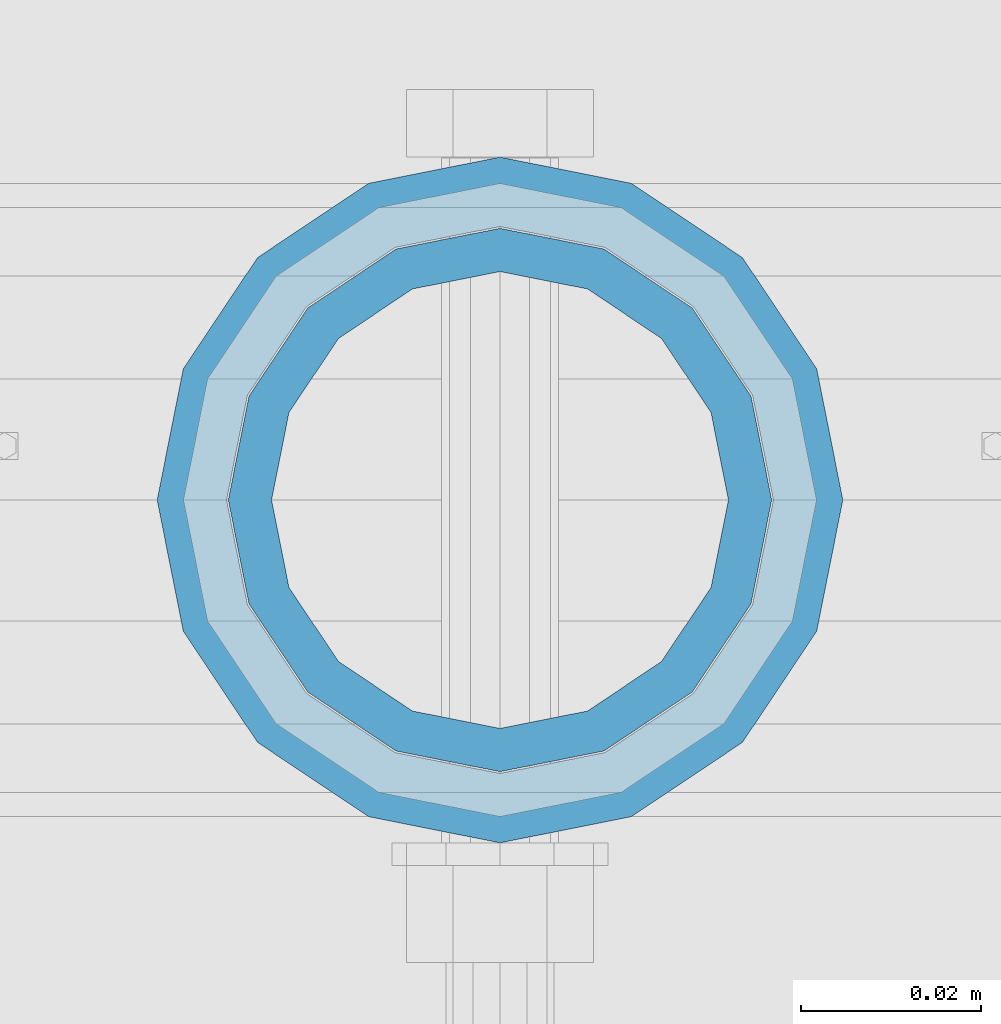
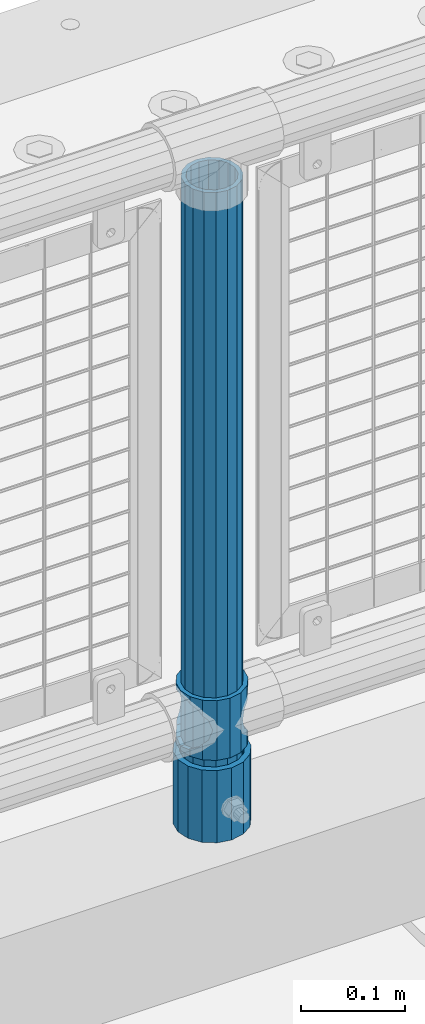
# One storey, part 66 of 219: 3 columns.
"""IFC2X3 building model written with IfcOpenShell, lengths in millimetres."""

import ifcopenshell
import ifcopenshell.guid

model = None  # the IFC model being written
_history = None  # IfcOwnerHistory: only IFC2X3 demands one
_inside = {}  # id of a spatial element -> (the spatial element, [elements in it])
_under = {}  # id of a project, library or spatial element -> (it, [spatial elements below it])
_declared = {}  # id of a project -> (the project, [libraries it declares])
_typed = {}  # id of a type object -> (the type object, [elements of that type])
_made_of = {}  # id of a material, layer set ... -> (it, [elements and type objects made of it])


def new_model(schema):
    """Start an empty IFC model of exactly this schema.

    Asked for "IFC4X3", IfcOpenShell would pick the latest addendum, in which some entities
    have other attributes; the version numbers below select the first issue.
    IFC2X3 requires an IfcOwnerHistory on every rooted entity: one is made here for all.
    """
    global model, _history
    if schema == "IFC4X3":
        model = ifcopenshell.file(schema_version=(4, 3, 0, 0))
    else:
        model = ifcopenshell.file(schema=schema)
    _inside.clear()
    _under.clear()
    _declared.clear()
    _typed.clear()
    _made_of.clear()
    _history = None
    if model.schema == "IFC2X3":
        org = make("IfcOrganization", Name="unknown")
        user = make(
            "IfcPersonAndOrganization",
            ThePerson=make("IfcPerson", FamilyName="unknown"),
            TheOrganization=org,
        )
        app = make(
            "IfcApplication",
            ApplicationDeveloper=org,
            Version="unknown",
            ApplicationFullName="unknown",
            ApplicationIdentifier="unknown",
        )
        _history = make(
            "IfcOwnerHistory",
            OwningUser=user,
            OwningApplication=app,
            ChangeAction="ADDED",
            CreationDate=0,
        )
    return model


def make(cls, **values):
    """One entity of the class cls with the attributes given. An attribute that is None is left unset."""
    return model.create_entity(
        cls, **{name: value for name, value in values.items() if value is not None}
    )


def rooted(cls, **values):
    """An entity with a GlobalId (a new one), such as an element, a storey or a relation."""
    return make(cls, GlobalId=ifcopenshell.guid.new(), OwnerHistory=_history, **values)


def si_unit(unit_type, name, prefix=None):
    """IfcSIUnit, for example si_unit("LENGTHUNIT", "METRE", prefix="MILLI")."""
    return make("IfcSIUnit", UnitType=unit_type, Prefix=prefix, Name=name)


def assignment(units):
    """IfcUnitAssignment: the units of a project."""
    return None if units is None else make("IfcUnitAssignment", Units=units)


def point(xyz):
    """IfcCartesianPoint."""
    return None if xyz is None else make("IfcCartesianPoint", Coordinates=xyz)


def direction(xyz):
    """IfcDirection."""
    return None if xyz is None else make("IfcDirection", DirectionRatios=xyz)


def frame(location, z_axis=None, x_axis=None):
    """IfcAxis2Placement3D, a coordinate frame: its origin and axes. An axis left out is left unset."""
    return make(
        "IfcAxis2Placement3D",
        Location=point(location),
        Axis=direction(z_axis),
        RefDirection=direction(x_axis),
    )


def origin_with_axes():
    """The frame at (0, 0, 0) with the z axis (0, 0, 1) and the x axis (1, 0, 0) written out."""
    return frame((0.0, 0.0, 0.0), z_axis=(0.0, 0.0, 1.0), x_axis=(1.0, 0.0, 0.0))


def place(relative_to, where):
    """IfcLocalPlacement: puts the frame where relative to a parent placement (None: the world)."""
    return make(
        "IfcLocalPlacement", PlacementRelTo=relative_to, RelativePlacement=where
    )


def context(
    kind, dimensions, precision=None, world=None, true_north=None, identifier=None
):
    """IfcGeometricRepresentationContext, for example the 3D "Model" context."""
    return make(
        "IfcGeometricRepresentationContext",
        ContextIdentifier=identifier,
        ContextType=kind,
        CoordinateSpaceDimension=dimensions,
        Precision=precision,
        WorldCoordinateSystem=world,
        TrueNorth=true_north,
    )


def subcontext(parent, identifier, kind, view, scale=None):
    """IfcGeometricRepresentationSubContext, for example "Body" below "Model"."""
    return make(
        "IfcGeometricRepresentationSubContext",
        ContextIdentifier=identifier,
        ContextType=kind,
        ParentContext=parent,
        TargetScale=scale,
        TargetView=view,
    )


def project(units=None, contexts=None):
    """IfcProject with its units and contexts."""
    return rooted(
        "IfcProject",
        Name="project",
        RepresentationContexts=contexts,
        UnitsInContext=assignment(units),
    )


def spatial(cls, under=None, at=None, **own):
    """A site, building, storey or space (cls), placed at a placement, below another one or the project."""
    s = rooted(cls, ObjectPlacement=at, **own)
    if under is not None:
        _under.setdefault(under.id(), (under, []))[1].append(s)
    return s


def faces_of(points, faces, orient=None, outer=None):
    """IfcFace entities. A face is a list of loops; a loop is a list of indices into points, from 0.

    orient and outer hold one flag for each loop. By default every Orientation is true, the
    first loop of a face is its IfcFaceOuterBound and the others are IfcFaceBound.
    """
    made = []
    for i, loops in enumerate(faces):
        bounds = []
        for j, loop in enumerate(loops):
            is_outer = j == 0 if outer is None else outer[i][j]
            bounds.append(
                make(
                    "IfcFaceOuterBound" if is_outer else "IfcFaceBound",
                    Bound=make("IfcPolyLoop", Polygon=[points[k] for k in loop]),
                    Orientation=True if orient is None else orient[i][j],
                )
            )
        made.append(make("IfcFace", Bounds=bounds))
    return made


def faceted_brep(points, faces, orient=None, outer=None, voids=None):
    """IfcFacetedBrep: a solid bounded by flat faces; with voids (closed shells), ...WithVoids."""
    shared = [point(p) for p in points]
    hull = make("IfcClosedShell", CfsFaces=faces_of(shared, faces, orient, outer))
    if voids is None:
        return make("IfcFacetedBrep", Outer=hull)
    return make(
        "IfcFacetedBrepWithVoids",
        Outer=hull,
        Voids=[
            make(cls, CfsFaces=faces_of(shared, fs, o, b)) for cls, fs, o, b in voids
        ],
    )


def shape(context_of_items, identifier, shape_type, items):
    """IfcShapeRepresentation: the items that make up one representation, for example the "Body"."""
    return make(
        "IfcShapeRepresentation",
        ContextOfItems=context_of_items,
        RepresentationIdentifier=identifier,
        RepresentationType=shape_type,
        Items=items,
    )


def material(Name=None, Category=None):
    """IfcMaterial."""
    return make("IfcMaterial", Name=Name, Category=Category)


def made_of(thing, what):
    """Note that an element or type object is made of a material, layer set ...; save() writes the relation."""
    if what is not None:
        _made_of.setdefault(what.id(), (what, []))[1].append(thing)
    return thing


def type_object(cls, material=None, **own):
    """A type object (cls), such as IfcWallType, which elements share."""
    return made_of(rooted(cls, **own), material)


def element(
    cls,
    number,
    at=None,
    inside=None,
    cuts=None,
    type_object=None,
    material=None,
    context=None,
    identifier="Body",
    shape_type=None,
    held_by="IfcProductDefinitionShape",
    body=None,
    shapes=None,
    **own,
):
    """One element of the class cls, such as IfcWall. Its Tag is "e" and its number.

    at: its placement. inside: the storey or other place that contains it. cuts: it is an
    opening in that element (IfcRelVoidsElement). A single representation is given by context,
    identifier, shape_type and body (its items); several are given by shapes. held_by: the class
    of the entity that holds the representations. save() writes the other relations.
    """
    e = rooted(cls, Tag="e%d" % number, ObjectPlacement=at, **own)
    if body is not None:
        shapes = [shape(context, identifier, shape_type, body)]
    if shapes is not None:
        e.Representation = make(held_by, Representations=shapes)
    if inside is not None:
        _inside.setdefault(inside.id(), (inside, []))[1].append(e)
    if cuts is not None:
        rooted(
            "IfcRelVoidsElement", RelatingBuildingElement=cuts, RelatedOpeningElement=e
        )
    if type_object is not None:
        _typed.setdefault(type_object.id(), (type_object, []))[1].append(e)
    return made_of(e, material)


def aggregate(whole, parts):
    """IfcRelAggregates: a whole, such as a stair, and the parts it consists of."""
    return rooted("IfcRelAggregates", RelatingObject=whole, RelatedObjects=parts)


def save(model, path):
    """Write the relations noted so far, then the file.

    IfcRelAggregates (storeys below a building ...), IfcRelContainedInSpatialStructure (elements
    in a storey), IfcRelDefinesByType, IfcRelAssociatesMaterial and IfcRelDeclares: one each for
    every whole, place, type object, material and project.
    """
    for whole, parts in _under.values():
        aggregate(whole, parts)
    for where, things in _inside.values():
        rooted(
            "IfcRelContainedInSpatialStructure",
            RelatedElements=things,
            RelatingStructure=where,
        )
    for kind, things in _typed.values():
        rooted("IfcRelDefinesByType", RelatedObjects=things, RelatingType=kind)
    for what, things in _made_of.values():
        rooted("IfcRelAssociatesMaterial", RelatedObjects=things, RelatingMaterial=what)
    for by, libraries in _declared.values():
        rooted("IfcRelDeclares", RelatingContext=by, RelatedDefinitions=libraries)
    model.write(path)


model = new_model("IFC2X3")

# Units and contexts
model_context = context("Model", 3, precision=1e-05, world=origin_with_axes())
body_context = subcontext(model_context, "Body", "Model", "MODEL_VIEW")
ifc_project = project(units=[si_unit("LENGTHUNIT", "METRE", prefix="MILLI"), si_unit("AREAUNIT", "SQUARE_METRE"), si_unit("VOLUMEUNIT", "CUBIC_METRE"), si_unit("MASSUNIT", "GRAM", prefix="KILO"), si_unit("TIMEUNIT", "SECOND"), si_unit("PLANEANGLEUNIT", "RADIAN"), si_unit("SOLIDANGLEUNIT", "STERADIAN"), si_unit("THERMODYNAMICTEMPERATUREUNIT", "DEGREE_CELSIUS"), si_unit("LUMINOUSINTENSITYUNIT", "LUMEN")], contexts=[model_context])

# Site, building, storey
site_placement = place(None, origin_with_axes())
site = spatial("IfcSite", under=ifc_project, at=site_placement, CompositionType="ELEMENT")
building_placement = place(site_placement, origin_with_axes())
building = spatial("IfcBuilding", under=site, at=building_placement, Name="Standard", CompositionType="ELEMENT")
storey_placement = place(building_placement, origin_with_axes())
storey = spatial("IfcBuildingStorey", under=building, at=storey_placement, Name="Undefined", CompositionType="ELEMENT", Elevation=0.0)

# Columns
ifc_material_1 = material(Name="Misc_Undefined")
column_type_1 = type_object("IfcColumnType", PredefinedType="NOTDEFINED")
column_1_placement = place(storey_placement, frame((2279.0, 31664.5, 263.02), z_axis=(-1.0, 0.0, 0.0), x_axis=(0.0, 0.0, 1.0)))
element("IfcColumn", 1, at=column_1_placement, inside=storey, type_object=column_type_1, material=ifc_material_1, context=body_context, shape_type="Brep", body=[
    faceted_brep([(56.6106908090114, 21.46069080901, -21.4606908090118), (56.6106908090114, 21.46069080901, -27.1226768591096), (61.9623795176703, 13.4513226476338, -32.4743655677721), (63.1897438117172, 11.614442172282, -32.8397438117172), (63.1897438117172, 11.614442172282, -28.0397438117179), (46.7644421722801, 28.0397438117179, -11.6144421722802), (46.7644421722801, 28.0397438117179, -20.0882031229849), (51.5310424080006, 24.8548033587067, -24.8548033587067), (35.1499999999996, 30.35, 0.0), (35.1499999999996, 30.3499999999985, -16.6306603983739), (23.5355578277192, 28.0397438117179, -11.6144421722802), (23.5355578277192, 28.0397438117179, -20.0882031229849), (13.6893091909879, 21.46069080901, -21.4606908090118), (13.6893091909879, 21.46069080901, -27.1226768591096), (18.7689575919987, 24.8548033587067, -24.8548033587067), (7.11025618828211, 11.614442172282, -28.0397438117179), (7.11025618828211, 11.614442172282, -32.8397438117172), (8.33762048232455, 13.4513226476338, -32.4743655677721), (4.79999999999961, 0.0, -30.3500000000004), (4.79999999999961, 0.0, -35.1499999999996), (7.11025618828211, -11.614442172282, -28.0397438117179), (7.11025618828211, -11.614442172282, -32.839743811719), (13.6893091909879, -21.46069080901, -21.4606908090118), (13.6893091909879, -21.46069080901, -27.1226768591077), (8.33762048232455, -13.4513226476338, -32.4743655677721), (23.5355578277191, -28.0397438117179, -11.6144421722802), (23.5355578277191, -28.0397438117179, -20.0882031229739), (18.7689575919921, -24.8548033587067, -24.8548033587067), (35.1499999999996, -30.35, 0.0), (35.1499999999996, -30.3499999999985, -16.6306603983649), (46.7644421722801, -28.0397438117179, -11.6144421722802), (46.7644421722801, -28.0397438117179, -20.0882031229739), (56.6106908090114, -21.46069080901, -21.4606908090118), (56.6106908090114, -21.46069080901, -27.1226768591077), (51.5310424080006, -24.8548033587067, -24.8548033587067), (63.1897438117172, -11.614442172282, -28.0397438117179), (63.1897438117172, -11.614442172282, -32.839743811719), (61.9623795176747, -13.4513226476338, -32.4743655677721), (65.4999999999997, 0.0, -30.3500000000004), (65.4999999999997, 0.0, -35.1499999999996), (0.0, -28.0397438117179, -11.6144421722802), (0.0, -30.3499999999985, 0.0), (0.0, -21.46069080901, -21.4606908090118), (0.0, -11.614442172282, -28.0397438117179), (0.0, 0.0, -30.3500000000004), (0.0, 11.614442172282, -28.0397438117179), (0.0, 21.46069080901, -21.4606908090118), (0.0, 28.0397438117179, -11.6144421722802), (0.0, 30.3499999999985, 0.0), (0.0, 28.0397438117179, 11.6144421722802), (23.5355578277192, 28.0397438117179, 11.6144421722806), (0.0, 21.46069080901, 21.4606908090118), (13.6893091909879, 21.46069080901, 21.4606908090118), (0.0, 11.614442172282, 28.0397438117179), (7.11025618828211, 11.614442172282, 28.0397438117175), (0.0, 0.0, 30.3500000000004), (4.79999999999961, 0.0, 30.3499999999999), (0.0, -11.614442172282, 28.0397438117179), (7.11025618828205, -11.614442172282, 28.0397438117175), (0.0, -21.46069080901, 21.4606908090118), (13.6893091909879, -21.46069080901, 21.4606908090118), (0.0, -28.0397438117179, 11.6144421722802), (23.5355578277191, -28.0397438117179, 11.6144421722806), (0.0, -32.4743655677703, 13.4513226476338), (0.0, -35.1500000000015, 0.0), (70.2999999999993, -35.1500000000015, 0.0), (70.2999999999993, -32.4743655677703, 13.4513226476338), (0.0, 13.4513226476338, -32.4743655677721), (0.0, 24.8548033587067, -24.8548033587067), (0.0, 0.0, -35.1500000000015), (0.0, -13.4513226476338, -32.4743655677721), (0.0, -24.8548033587067, -24.8548033587067), (0.0, -24.8548033587067, 24.8548033587067), (0.0, -13.4513226476338, 32.4743655677721), (0.0, 0.0, 35.1500000000015), (0.0, 13.4513226476338, 32.4743655677721), (0.0, 24.8548033587067, 24.8548033587067), (0.0, 32.4743655677703, 13.4513226476338), (0.0, 35.1500000000015, 0.0), (0.0, 32.4743655677703, -13.4513226476338), (0.0, -32.4743655677703, -13.4513226476338), (70.2999999999993, 32.4743655677703, 13.4513226476338), (70.2999999999993, 35.1500000000015, 0.0), (70.2999999999993, 32.4743655677703, -13.4513226476338), (70.2999999999993, 24.8548033587067, -24.8548033587067), (70.2999999999993, 13.4513226476338, -32.4743655677721), (70.2999999999993, 0.0, -35.1499999999996), (70.2999999999993, -13.4513226476338, -32.4743655677721), (70.2999999999993, -24.8548033587067, -24.8548033587067), (70.2999999999993, -32.4743655677703, -13.4513226476338), (70.2999999999993, 28.0397438117179, 11.6144421722802), (70.2999999999993, 21.46069080901, 21.4606908090118), (56.6106908090114, 21.46069080901, 21.4606908090118), (46.7644421722801, 28.0397438117179, 11.6144421722806), (70.2999999999993, 11.614442172282, 28.0397438117179), (63.1897438117172, 11.614442172282, 28.0397438117175), (70.2999999999993, 0.0, 30.3500000000004), (65.4999999999997, 0.0, 30.3499999999999), (70.2999999999993, -11.614442172282, 28.0397438117179), (63.1897438117172, -11.614442172282, 28.0397438117175), (70.2999999999993, -21.46069080901, 21.4606908090118), (56.6106908090114, -21.46069080901, 21.4606908090118), (70.2999999999993, -28.0397438117179, 11.6144421722802), (46.7644421722801, -28.0397438117179, 11.6144421722806), (70.2999999999993, -11.614442172282, -28.0397438117179), (70.2999999999993, 0.0, -30.3500000000004), (70.2999999999993, -21.46069080901, -21.4606908090118), (70.2999999999993, -28.0397438117179, -11.6144421722802), (70.2999999999993, -30.3499999999985, 0.0), (70.2999999999993, 24.8548033587067, 24.8548033587067), (70.2999999999993, 13.4513226476338, 32.4743655677721), (70.2999999999993, 0.0, 35.1499999999996), (70.2999999999993, -13.4513226476338, 32.4743655677721), (70.2999999999993, -24.8548033587067, 24.8548033587067), (70.2999999999993, 30.3499999999985, 0.0), (70.2999999999993, 28.0397438117179, -11.6144421722802), (70.2999999999993, 21.46069080901, -21.4606908090118), (70.2999999999993, 11.614442172282, -28.0397438117179), (61.9623795176742, 13.4513226476338, 32.4743655677717), (51.5310424080006, 24.8548033587067, 24.8548033587072), (56.6106908090114, 21.46069080901, 27.1226768591059), (65.4999999999997, 0.0, 35.1500000000001), (63.1897438117172, 11.614442172282, 32.8397438117177), (63.1897438117172, -11.614442172282, 32.8397438117177), (61.9623795176742, -13.4513226476338, 32.4743655677717), (56.6106908090114, -21.46069080901, 27.1226768591087), (51.5310424080006, -24.8548033587067, 24.8548033587072), (18.7689575919921, -24.8548033587067, 24.8548033587072), (46.7644421722801, -28.0397438117179, 20.0882031229862), (35.1499999999996, -30.3499999999985, 16.630660398373), (23.5355578277191, -28.0397438117179, 20.0882031229862), (8.33762048232506, -13.4513226476338, 32.4743655677717), (13.6893091909879, -21.46069080901, 27.1226768591087), (4.79999999999961, 0.0, 35.1500000000001), (7.11025618828205, -11.614442172282, 32.8397438117177), (7.11025618828211, 11.614442172282, 32.8397438117177), (8.33762048232069, 13.4513226476338, 32.4743655677717), (13.6893091909879, 21.46069080901, 27.1226768591059), (18.7689575919987, 24.8548033587067, 24.8548033587072), (23.5355578277192, 28.0397438117179, 20.0882031229794), (35.1499999999996, 30.3499999999985, 16.6306603983667), (46.7644421722801, 28.0397438117179, 20.0882031229794)], [[[0, 1, 2, 3, 4]], [[5, 6, 7, 1, 0]], [[8, 9, 6, 5]], [[10, 11, 9, 8]], [[12, 13, 14, 11, 10]], [[15, 16, 17, 13, 12]], [[18, 19, 16, 15]], [[20, 21, 19, 18]], [[22, 23, 24, 21, 20]], [[25, 26, 27, 23, 22]], [[28, 29, 26, 25]], [[30, 31, 29, 28]], [[32, 33, 34, 31, 30]], [[35, 36, 37, 33, 32]], [[38, 39, 36, 35]], [[4, 3, 39, 38]], [[40, 41, 28, 25]], [[42, 40, 25, 22]], [[43, 42, 22, 20]], [[44, 43, 20, 18]], [[45, 44, 18, 15]], [[46, 45, 15, 12]], [[47, 46, 12, 10]], [[48, 47, 10, 8]], [[49, 48, 8, 50]], [[51, 49, 50, 52]], [[53, 51, 52, 54]], [[55, 53, 54, 56]], [[57, 55, 56, 58]], [[59, 57, 58, 60]], [[61, 59, 60, 62]], [[41, 61, 62, 28]], [[63, 64, 65, 66]], [[17, 67, 68, 14, 13]], [[19, 69, 67, 17, 16]], [[70, 69, 19, 21, 24]], [[71, 70, 24, 23, 27]], [[63, 72, 73, 74, 75, 76, 77, 78, 79, 68, 67, 69, 70, 71, 80, 64], [40, 42, 43, 44, 45, 46, 47, 48, 49, 51, 53, 55, 57, 59, 61, 41]], [[78, 77, 81, 82]], [[79, 78, 82, 83]], [[14, 68, 79, 83, 84, 7, 6, 9, 11]], [[84, 85, 2, 1, 7]], [[85, 86, 39, 3, 2]], [[37, 87, 88, 34, 33]], [[39, 86, 87, 37, 36]], [[34, 88, 89, 80, 71, 27, 26, 29, 31]], [[64, 80, 89, 65]], [[90, 91, 92, 93]], [[91, 94, 95, 92]], [[94, 96, 97, 95]], [[96, 98, 99, 97]], [[98, 100, 101, 99]], [[100, 102, 103, 101]], [[104, 105, 38, 35]], [[106, 104, 35, 32]], [[107, 106, 32, 30]], [[108, 107, 30, 28]], [[102, 108, 28, 103]], [[88, 87, 86, 85, 84, 83, 82, 81, 109, 110, 111, 112, 113, 66, 65, 89], [100, 98, 96, 94, 91, 90, 114, 115, 116, 117, 105, 104, 106, 107, 108, 102]], [[118, 110, 109, 119, 120]], [[121, 111, 110, 118, 122]], [[112, 111, 121, 123, 124]], [[113, 112, 124, 125, 126]], [[127, 72, 63, 66, 113, 126, 128, 129, 130]], [[131, 73, 72, 127, 132]], [[133, 74, 73, 131, 134]], [[75, 74, 133, 135, 136]], [[76, 75, 136, 137, 138]], [[119, 109, 81, 77, 76, 138, 139, 140, 141]], [[92, 120, 119, 141, 93]], [[95, 122, 118, 120, 92]], [[97, 121, 122, 95]], [[99, 123, 121, 97]], [[101, 125, 124, 123, 99]], [[103, 128, 126, 125, 101]], [[28, 129, 128, 103]], [[62, 130, 129, 28]], [[60, 132, 127, 130, 62]], [[58, 134, 131, 132, 60]], [[56, 133, 134, 58]], [[54, 135, 133, 56]], [[52, 137, 136, 135, 54]], [[50, 139, 138, 137, 52]], [[8, 140, 139, 50]], [[93, 141, 140, 8]], [[114, 90, 93, 8]], [[115, 114, 8, 5]], [[116, 115, 5, 0]], [[117, 116, 0, 4]], [[105, 117, 4, 38]]]),
])
ifc_material_2 = material()
column_type_2 = type_object("IfcColumnType", PredefinedType="NOTDEFINED")
column_2_placement = place(storey_placement, frame((2279.0, 31664.5, 168.02), z_axis=(-1.0, 0.0, 0.0), x_axis=(0.0, 0.0, 1.0)))
element("IfcColumn", 2, at=column_2_placement, inside=storey, type_object=column_type_2, material=ifc_material_2, context=body_context, shape_type="Brep", body=[
    faceted_brep([(0.0, -25.3499999999985, 0.0), (0.0, -23.4203461491597, 9.70102501045585), (760.0, -23.4203461491597, 9.70102501045585), (760.0, -25.3499999999985, 0.0), (0.0, -17.9251569030785, 17.9251569030785), (760.0, -17.9251569030785, 17.9251569030785), (0.0, -9.70102501045403, 23.4203461491616), (760.0, -9.70102501045403, 23.4203461491616), (0.0, 0.0, 25.3500000000004), (760.0, 0.0, 25.3500000000004), (0.0, 9.70102501045403, 23.4203461491616), (760.0, 9.70102501045403, 23.4203461491616), (0.0, 17.9251569030785, 17.9251569030785), (760.0, 17.9251569030785, 17.9251569030785), (0.0, 23.4203461491597, 9.70102501045585), (760.0, 23.4203461491597, 9.70102501045585), (0.0, 25.3499999999985, 0.0), (760.0, 25.3499999999985, 0.0), (0.0, 23.4203461491597, -9.70102501045585), (760.0, 23.4203461491597, -9.70102501045585), (0.0, 17.9251569030785, -17.9251569030785), (760.0, 17.9251569030785, -17.9251569030785), (0.0, 9.70102501045403, -23.4203461491616), (760.0, 9.70102501045403, -23.4203461491616), (0.0, 0.0, -25.3500000000004), (760.0, 0.0, -25.3500000000004), (0.0, -9.70102501045403, -23.4203461491616), (760.0, -9.70102501045403, -23.4203461491616), (0.0, -17.9251569030785, -17.9251569030785), (760.0, -17.9251569030785, -17.9251569030785), (0.0, -23.4203461491597, -9.70102501045585), (760.0, -23.4203461491597, -9.70102501045585), (0.0, -30.1500000000015, 0.0), (0.0, -27.8549679052157, -11.5379054858076), (760.0, -27.8549679052157, -11.5379054858076), (760.0, -30.1500000000015, 0.0), (0.0, -21.3192694527752, -21.3192694527752), (760.0, -21.3192694527752, -21.3192694527752), (0.0, -11.5379054858058, -27.8549679052157), (760.0, -11.5379054858058, -27.8549679052157), (0.0, 0.0, -30.1499999999996), (760.0, 0.0, -30.1499999999996), (0.0, 11.5379054858058, -27.8549679052157), (760.0, 11.5379054858058, -27.8549679052157), (0.0, 21.3192694527752, -21.3192694527752), (760.0, 21.3192694527752, -21.3192694527752), (0.0, 27.8549679052157, -11.5379054858076), (760.0, 27.8549679052157, -11.5379054858076), (0.0, 30.1500000000015, 0.0), (760.0, 30.1500000000015, 0.0), (0.0, 27.8549679052157, 11.5379054858076), (760.0, 27.8549679052157, 11.5379054858076), (0.0, 21.3192694527752, 21.3192694527752), (760.0, 21.3192694527752, 21.3192694527752), (0.0, 11.5379054858058, 27.8549679052157), (760.0, 11.5379054858058, 27.8549679052157), (0.0, 0.0, 30.1499999999996), (760.0, 0.0, 30.1499999999996), (0.0, -11.5379054858058, 27.8549679052157), (760.0, -11.5379054858058, 27.8549679052157), (0.0, -21.3192694527752, 21.3192694527752), (760.0, -21.3192694527752, 21.3192694527752), (0.0, -27.8549679052157, 11.5379054858076), (760.0, -27.8549679052157, 11.5379054858076)], [[[0, 1, 2, 3]], [[1, 4, 5, 2]], [[4, 6, 7, 5]], [[6, 8, 9, 7]], [[8, 10, 11, 9]], [[10, 12, 13, 11]], [[12, 14, 15, 13]], [[14, 16, 17, 15]], [[16, 18, 19, 17]], [[18, 20, 21, 19]], [[20, 22, 23, 21]], [[22, 24, 25, 23]], [[24, 26, 27, 25]], [[26, 28, 29, 27]], [[28, 30, 31, 29]], [[30, 0, 3, 31]], [[32, 33, 34, 35]], [[33, 36, 37, 34]], [[36, 38, 39, 37]], [[38, 40, 41, 39]], [[40, 42, 43, 41]], [[42, 44, 45, 43]], [[44, 46, 47, 45]], [[46, 48, 49, 47]], [[48, 50, 51, 49]], [[50, 52, 53, 51]], [[52, 54, 55, 53]], [[54, 56, 57, 55]], [[56, 58, 59, 57]], [[58, 60, 61, 59]], [[60, 62, 63, 61]], [[62, 32, 35, 63]], [[37, 39, 41, 43, 45, 47, 49, 51, 53, 55, 57, 59, 61, 63, 35, 34], [5, 7, 9, 11, 13, 15, 17, 19, 21, 23, 25, 27, 29, 31, 3, 2]], [[62, 60, 58, 56, 54, 52, 50, 48, 46, 44, 42, 40, 38, 36, 33, 32], [30, 28, 26, 24, 22, 20, 18, 16, 14, 12, 10, 8, 6, 4, 1, 0]]]),
])
column_type_3 = type_object("IfcColumnType", PredefinedType="NOTDEFINED")
column_3_placement = place(storey_placement, frame((2279.0, 31664.5, 168.02), z_axis=(0.0, 1.0, 0.0), x_axis=(0.0, 0.0, 1.0)))
element("IfcColumn", 3, at=column_3_placement, inside=storey, type_object=column_type_3, material=ifc_material_2, context=body_context, shape_type="Brep", body=[
    faceted_brep([(0.0, -31.75, 0.0), (0.0, -29.3331751572332, 12.1501989775934), (85.0, -29.3331751572332, 12.1501989775934), (85.0, -31.75, 0.0), (0.0, -22.4506403026735, 22.4506403026717), (85.0, -22.4506403026735, 22.4506403026717), (0.0, -12.1501989775916, 29.3331751572332), (85.0, -12.1501989775916, 29.3331751572332), (0.0, 0.0, 31.75), (85.0, 0.0, 31.75), (0.0, 12.1501989775916, 29.3331751572332), (85.0, 12.1501989775916, 29.3331751572332), (0.0, 22.4506403026735, 22.4506403026717), (85.0, 22.4506403026735, 22.4506403026717), (0.0, 29.3331751572332, 12.1501989775934), (85.0, 29.3331751572332, 12.1501989775934), (0.0, 31.75, 0.0), (85.0, 31.75, 0.0), (0.0, 29.3331751572332, -12.1501989775934), (85.0, 29.3331751572332, -12.1501989775934), (0.0, 22.4506403026735, -22.4506403026717), (85.0, 22.4506403026735, -22.4506403026717), (0.0, 12.1501989775916, -29.3331751572332), (85.0, 12.1501989775916, -29.3331751572332), (0.0, 0.0, -31.75), (85.0, 0.0, -31.75), (0.0, -12.1501989775916, -29.3331751572332), (85.0, -12.1501989775916, -29.3331751572332), (0.0, -22.4506403026735, -22.4506403026717), (85.0, -22.4506403026735, -22.4506403026717), (0.0, -29.3331751572332, -12.1501989775934), (85.0, -29.3331751572332, -12.1501989775934), (0.0, -38.0499999999993, 0.0), (0.0, -35.1536162120537, -14.5611046014928), (85.0, -35.1536162120537, -14.5611046014928), (85.0, -38.0499999999993, 0.0), (0.0, -26.9054130241475, -26.9054130241493), (85.0, -26.9054130241475, -26.9054130241493), (0.0, -14.561104601491, -35.1536162120537), (85.0, -14.561104601491, -35.1536162120537), (0.0, 0.0, -38.0499999999993), (85.0, 0.0, -38.0499999999993), (0.0, 14.561104601491, -35.1536162120537), (85.0, 14.561104601491, -35.1536162120537), (0.0, 26.9054130241475, -26.9054130241493), (85.0, 26.9054130241475, -26.9054130241493), (0.0, 35.1536162120537, -14.5611046014928), (85.0, 35.1536162120537, -14.5611046014928), (0.0, 38.0499999999993, 0.0), (85.0, 38.0499999999993, 0.0), (0.0, 35.1536162120537, 14.5611046014928), (85.0, 35.1536162120537, 14.5611046014928), (0.0, 26.9054130241475, 26.9054130241493), (85.0, 26.9054130241475, 26.9054130241493), (0.0, 14.561104601491, 35.1536162120537), (85.0, 14.561104601491, 35.1536162120537), (0.0, 0.0, 38.0499999999993), (85.0, 0.0, 38.0499999999993), (0.0, -14.561104601491, 35.1536162120537), (85.0, -14.561104601491, 35.1536162120537), (0.0, -26.9054130241475, 26.9054130241493), (85.0, -26.9054130241475, 26.9054130241493), (0.0, -35.1536162120537, 14.5611046014928), (85.0, -35.1536162120537, 14.5611046014928)], [[[0, 1, 2, 3]], [[1, 4, 5, 2]], [[4, 6, 7, 5]], [[6, 8, 9, 7]], [[8, 10, 11, 9]], [[10, 12, 13, 11]], [[12, 14, 15, 13]], [[14, 16, 17, 15]], [[16, 18, 19, 17]], [[18, 20, 21, 19]], [[20, 22, 23, 21]], [[22, 24, 25, 23]], [[24, 26, 27, 25]], [[26, 28, 29, 27]], [[28, 30, 31, 29]], [[30, 0, 3, 31]], [[32, 33, 34, 35]], [[33, 36, 37, 34]], [[36, 38, 39, 37]], [[38, 40, 41, 39]], [[40, 42, 43, 41]], [[42, 44, 45, 43]], [[44, 46, 47, 45]], [[46, 48, 49, 47]], [[48, 50, 51, 49]], [[50, 52, 53, 51]], [[52, 54, 55, 53]], [[54, 56, 57, 55]], [[56, 58, 59, 57]], [[58, 60, 61, 59]], [[60, 62, 63, 61]], [[62, 32, 35, 63]], [[37, 39, 41, 43, 45, 47, 49, 51, 53, 55, 57, 59, 61, 63, 35, 34], [5, 7, 9, 11, 13, 15, 17, 19, 21, 23, 25, 27, 29, 31, 3, 2]], [[62, 60, 58, 56, 54, 52, 50, 48, 46, 44, 42, 40, 38, 36, 33, 32], [30, 28, 26, 24, 22, 20, 18, 16, 14, 12, 10, 8, 6, 4, 1, 0]]]),
])

save(model, "model.ifc")
